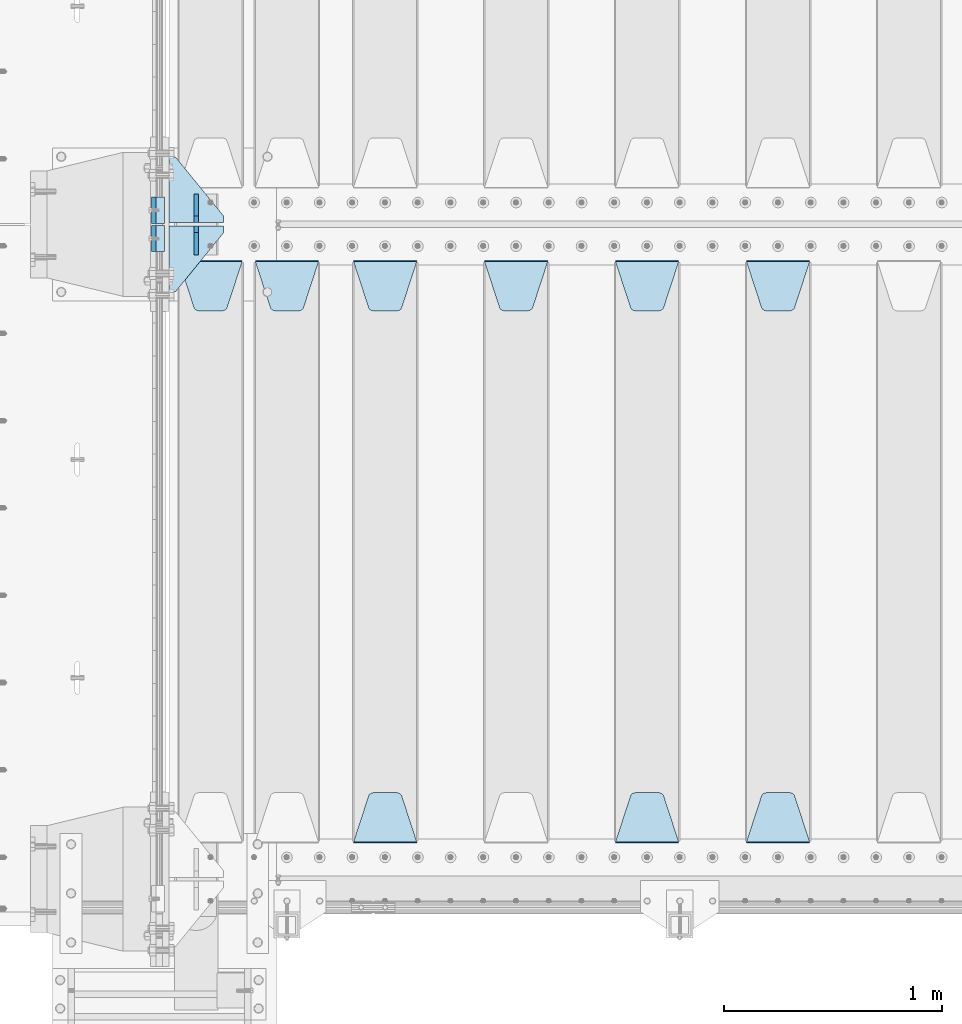
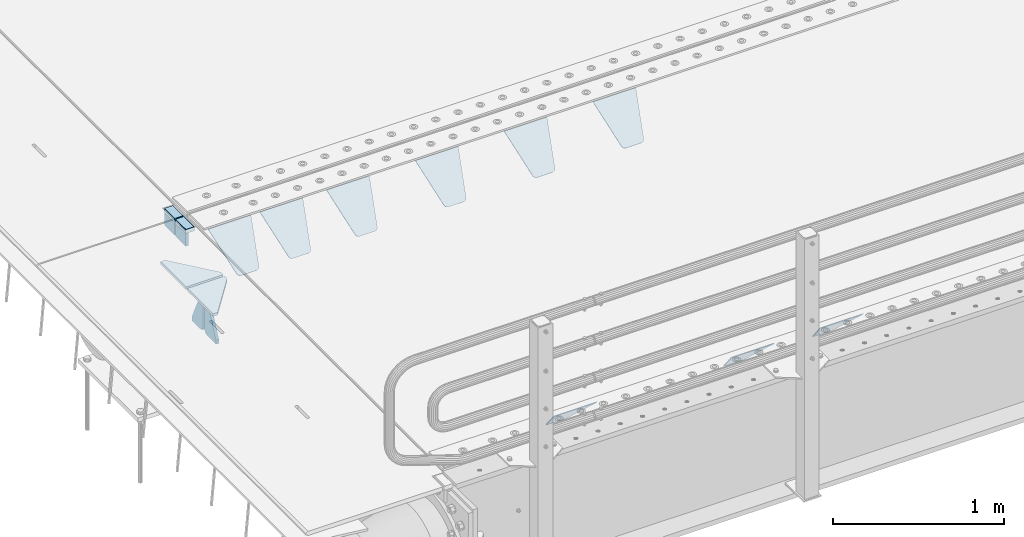
# One storey, part 215 of 270: 17 plates.
"""IFC2X3 building model written with IfcOpenShell, lengths in millimetres."""

from ifc_helpers import new_model, si_unit, frame, origin_with_axes, place, context, subcontext, project, spatial, faceted_brep, material, type_object, element, save


model = new_model("IFC2X3")

# Units and contexts
model_context = context("Model", 3, precision=1e-05, world=origin_with_axes())
body_context = subcontext(model_context, "Body", "Model", "MODEL_VIEW")
ifc_project = project(units=[si_unit("LENGTHUNIT", "METRE", prefix="MILLI"), si_unit("AREAUNIT", "SQUARE_METRE"), si_unit("VOLUMEUNIT", "CUBIC_METRE"), si_unit("MASSUNIT", "GRAM", prefix="KILO"), si_unit("TIMEUNIT", "SECOND"), si_unit("PLANEANGLEUNIT", "RADIAN"), si_unit("SOLIDANGLEUNIT", "STERADIAN"), si_unit("THERMODYNAMICTEMPERATUREUNIT", "DEGREE_CELSIUS"), si_unit("LUMINOUSINTENSITYUNIT", "LUMEN")], contexts=[model_context])

# Site, building, storey
site_placement = place(None, origin_with_axes())
site = spatial("IfcSite", under=ifc_project, at=site_placement, CompositionType="ELEMENT")
building_placement = place(site_placement, origin_with_axes())
building = spatial("IfcBuilding", under=site, at=building_placement, Name="Standard", CompositionType="ELEMENT")
storey_placement = place(building_placement, origin_with_axes())
storey = spatial("IfcBuildingStorey", under=building, at=storey_placement, Name="Undefined", CompositionType="ELEMENT", Elevation=0.0)

# Plates
ifc_material_1 = material()
plate_type_1 = type_object("IfcPlateType", PredefinedType="NOTDEFINED")
plate_1_placement = place(storey_placement, frame((-10.0000000000014, -21064.9999999999, -16.0000945328909), z_axis=(-1.0, 0.0, 0.0), x_axis=(0.0, 0.0, 1.0)))
element("IfcPlate", 1, at=plate_1_placement, inside=storey, type_object=plate_type_1, material=ifc_material_1, context=body_context, shape_type="Brep", body=[
    faceted_brep([(1.77635683940025e-15, -60.0000000000073, 0.0), (2.49929321682885e-09, -60.0000000000073, 60.0), (2.49928966411517e-09, 59.9999999999964, 60.0), (-1.77635683940025e-15, 59.9999999999964, 0.0), (25.0146748218828, -60.0000000000073, 60.0), (25.0146748218828, 59.9999999999927, 60.0), (26.5597449794466, -60.0000000000073, 59.7552873949117), (26.5597449794466, 59.9999999999964, 59.7552873949117), (27.9535758796897, -60.0000000000036, 59.0451032832824), (27.9535758796897, 59.9999999999964, 59.0451032832824), (29.0597323263517, -60.0000000000073, 57.9389640667317), (29.0597323263517, 59.9999999999927, 57.9389640667317), (29.7699381491534, -60.0000000000036, 56.5451442289687), (29.7699381491534, 59.9999999999927, 56.5451442289687), (30.0146748212763, -60.0000000000073, 55.0000778834025), (30.0146748212762, 59.9999999999927, 55.0000778834025), (30.0154536553013, -60.0000000000036, 5.00007788340855), (30.0154536553013, 59.9999999999964, 5.00007788340855), (29.7707554908505, -60.0000000000073, 3.45497428546548), (29.7707554908505, 59.9999999999927, 3.45497428546548), (29.0605660948355, -60.0000000000073, 2.06111154407017), (29.0605660948355, 59.9999999999927, 2.06111154407017), (27.9544051209123, -60.0000000000036, 0.954933339696428), (27.9544051209123, 59.9999999999964, 0.954933339696428), (26.5605534420796, -60.0000000000036, 0.244722232012666), (26.5605534420796, 59.9999999999964, 0.244722232012666), (25.0154536559091, -60.0000000000073, 6.05382410867605e-12), (25.0154536559091, 59.9999999999927, 6.05382410867605e-12)], [[[0, 1, 2, 3]], [[1, 4, 5, 2]], [[4, 6, 7, 5]], [[6, 8, 9, 7]], [[8, 10, 11, 9]], [[10, 12, 13, 11]], [[12, 14, 15, 13]], [[14, 16, 17, 15]], [[16, 18, 19, 17]], [[18, 20, 21, 19]], [[20, 22, 23, 21]], [[22, 24, 25, 23]], [[24, 26, 27, 25]], [[26, 0, 3, 27]], [[5, 7, 9, 11, 13, 15, 17, 19, 21, 23, 25, 27, 3, 2]], [[26, 24, 22, 20, 18, 16, 14, 12, 10, 8, 6, 4, 1, 0]]]),
])
plate_2_placement = place(storey_placement, frame((-10.0000000600267, -20934.9999995478, -16.0145962164398), z_axis=(-1.0, 0.0, 0.0), x_axis=(0.0, -4.95099997756316e-06, 0.999999999987744)))
element("IfcPlate", 2, at=plate_2_placement, inside=storey, type_object=plate_type_1, material=ifc_material_1, context=body_context, shape_type="Brep", body=[
    faceted_brep([(1.77635683940025e-15, -60.0000000000073, 0.0), (-0.000933120085688799, -60.0000000000036, 60.0), (-0.000933120085688799, 59.9999999999964, 60.0), (-1.77635683940025e-15, 59.9999999999964, 0.0), (24.9991450303709, -60.0, 60.0), (24.9991450303709, 59.9999999999964, 60.0), (26.544215218168, -60.0000000000036, 59.7552873850884), (26.544215218168, 60.0, 59.7552873850884), (27.9380461396139, -60.0000000000036, 59.0451032459123), (27.9380461396139, 60.0, 59.0451032459123), (29.0442025908961, -60.0000000000036, 57.9389639895784), (29.0442025908961, 60.0, 57.9389639895784), (29.7544083969366, -60.0, 56.5451441080361), (29.7544083969366, 60.0000000000036, 56.5451441080361), (29.9991450297669, -60.0000000000036, 55.0000777244568), (29.9991450297669, 60.0, 55.0000777244568), (29.999922274335, -60.0, 5.00007772445705), (29.999922274335, 60.0, 5.00007772445704), (29.7552240705896, -60.0000000000036, 3.45497416452589), (29.7552240705896, 60.0, 3.45497416452589), (29.0450346578116, -60.0, 2.06111146690959), (29.0450346578116, 59.9999999999964, 2.0611114669096), (27.9388736885072, -60.0, 0.954933302319514), (27.9388736885072, 59.9999999999964, 0.954933302319516), (26.5450220308766, -60.0000000000036, 0.244722222183089), (26.5450220308766, 60.0, 0.244722222183091), (24.9999222749392, -60.0, 2.66453525910038e-13), (24.9999222749392, 60.0, 2.66453525910038e-13)], [[[0, 1, 2, 3]], [[1, 4, 5, 2]], [[4, 6, 7, 5]], [[6, 8, 9, 7]], [[8, 10, 11, 9]], [[10, 12, 13, 11]], [[12, 14, 15, 13]], [[14, 16, 17, 15]], [[16, 18, 19, 17]], [[18, 20, 21, 19]], [[20, 22, 23, 21]], [[22, 24, 25, 23]], [[24, 26, 27, 25]], [[26, 0, 3, 27]], [[5, 7, 9, 11, 13, 15, 17, 19, 21, 23, 25, 27, 3, 2]], [[26, 24, 22, 20, 18, 16, 14, 12, 10, 8, 6, 4, 1, 0]]]),
])
ifc_material_2 = material(Name="STEEL/S355N")
plate_type_2 = type_object("IfcPlateType", PredefinedType="NOTDEFINED")
plate_3_placement = place(storey_placement, frame((-60.000000000005, -21004.9999144655, -105.984429072951), z_axis=(0.0, -1.0, 0.0), x_axis=(0.0, 0.0, 1.0)))
element("IfcPlate", 3, at=plate_3_placement, inside=storey, type_object=plate_type_2, material=ifc_material_2, context=body_context, shape_type="Brep", body=[
    faceted_brep([(0.0, -10.0, 0.0), (4.30830482400779e-10, -10.0, 120.000000000004), (4.30830482400779e-10, 10.0, 120.000000000004), (0.0, 10.0, 0.0), (89.9845046997066, -10.0, 120.0), (89.9845046997066, 10.0, 120.0), (89.9843902587891, -10.0, 6.54836185276508e-11), (89.9843902587891, 10.0, 6.54836185276508e-11)], [[[0, 1, 2, 3]], [[1, 4, 5, 2]], [[4, 6, 7, 5]], [[6, 0, 3, 7]], [[5, 7, 3, 2]], [[6, 4, 1, 0]]]),
])
plate_4_placement = place(storey_placement, frame((-60.0, -20874.9995539981, -106.014921246643), z_axis=(0.0, -0.999999999987744, -4.95099999993769e-06), x_axis=(0.0, -4.95099997756316e-06, 0.999999999987744)))
element("IfcPlate", 4, at=plate_4_placement, inside=storey, type_object=plate_type_2, material=ifc_material_2, context=body_context, shape_type="Brep", body=[
    faceted_brep([(0.0, -10.0, 0.0), (4.30830482400779e-10, -10.0, 120.000000000004), (4.30830482400779e-10, 10.0, 120.000000000004), (0.0, 10.0, 0.0), (89.9999999999979, -10.0, 120.000000000004), (89.9999999999979, 10.0, 120.000000000004), (90.0, -10.0, 1.09139364212751e-11), (90.0, 10.0, 1.09139364212751e-11)], [[[0, 1, 2, 3]], [[1, 4, 5, 2]], [[4, 6, 7, 5]], [[6, 0, 3, 7]], [[5, 7, 3, 2]], [[6, 4, 1, 0]]]),
])
plate_type_3 = type_object("IfcPlateType", PredefinedType="NOTDEFINED")
plate_5_placement = place(storey_placement, frame((2655.0, -21168.232233044, -1.76776695296576), z_axis=(0.0, -0.707106781186548, -0.707106781186547), x_axis=(1.0, 0.0, 0.0)))
element("IfcPlate", 5, at=plate_5_placement, inside=storey, type_object=plate_type_3, material=ifc_material_2, context=body_context, shape_type="Brep", body=[
    faceted_brep([(0.0, -2.5, 0.0), (69.345504679477, -2.5, 300.171731424831), (69.345504679477, 2.5, 300.171731424831), (0.0, 2.5, 0.0), (70.9274061199576, -2.5, 304.8974424154), (70.9274061199576, 2.5, 304.8974424154), (73.3818627772307, -2.49999999999818, 309.234538108527), (73.3818627772307, 2.50000000000182, 309.234538108527), (76.6187032999551, -2.5, 313.023683126103), (76.6187032999551, 2.5, 313.023683126103), (80.5190132704993, -2.5, 316.125672595372), (80.5190132704993, 2.50000000000182, 316.125672595372), (84.9395038596849, -2.49999999999818, 318.426546230476), (84.9395038596849, 2.5, 318.426546230476), (89.7177759439219, -2.49999999999818, 319.841774983275), (89.7177759439219, 2.50000000000182, 319.841774983275), (94.678286292652, -2.5, 320.319366455078), (94.678286292652, 2.5, 320.319366455078), (195.321713707348, -2.5, 320.319366455078), (195.321713707348, 2.5, 320.319366455078), (200.282224056078, -2.49999999999818, 319.841774983275), (200.282224056078, 2.50000000000182, 319.841774983275), (205.060496140315, -2.5, 318.426546230476), (205.060496140315, 2.5, 318.426546230476), (209.480986729501, -2.5, 316.12567259537), (209.480986729501, 2.50000000000182, 316.12567259537), (213.381296700045, -2.5, 313.023683126103), (213.381296700045, 2.5, 313.023683126103), (216.618137222769, -2.49999999999818, 309.234538108525), (216.618137222769, 2.50000000000182, 309.234538108527), (219.072593880042, -2.49999999999818, 304.897442415398), (219.072593880042, 2.50000000000182, 304.897442415397), (220.654495320523, -2.5, 300.171731424831), (220.654495320523, 2.5, 300.171731424831), (290.0, -2.49999999999818, 0.0), (290.0, 2.5, 0.0)], [[[0, 1, 2, 3]], [[1, 4, 5, 2]], [[4, 6, 7, 5]], [[6, 8, 9, 7]], [[8, 10, 11, 9]], [[10, 12, 13, 11]], [[12, 14, 15, 13]], [[14, 16, 17, 15]], [[16, 18, 19, 17]], [[18, 20, 21, 19]], [[20, 22, 23, 21]], [[22, 24, 25, 23]], [[24, 26, 27, 25]], [[26, 28, 29, 27]], [[28, 30, 31, 29]], [[30, 32, 33, 31]], [[32, 34, 35, 33]], [[34, 0, 3, 35]], [[5, 7, 9, 11, 13, 15, 17, 19, 21, 23, 25, 27, 29, 31, 33, 35, 3, 2]], [[34, 32, 30, 28, 26, 24, 22, 20, 18, 16, 14, 12, 10, 8, 6, 4, 1, 0]]]),
])
plate_6_placement = place(storey_placement, frame((2945.0, -23831.767766953, -1.76776695296758), z_axis=(0.0, 0.707106781186547, -0.707106781186548), x_axis=(-1.0, 0.0, 0.0)))
element("IfcPlate", 6, at=plate_6_placement, inside=storey, type_object=plate_type_3, material=ifc_material_2, context=body_context, shape_type="Brep", body=[
    faceted_brep([(0.0, -2.5, 0.0), (69.345504679477, -2.5, 300.171731424831), (69.345504679477, 2.5, 300.171731424831), (0.0, 2.5, 0.0), (70.9274061199576, -2.5, 304.8974424154), (70.9274061199576, 2.5, 304.8974424154), (73.3818627772307, -2.49999999999818, 309.234538108527), (73.3818627772307, 2.50000000000182, 309.234538108527), (76.6187032999551, -2.5, 313.023683126103), (76.6187032999551, 2.5, 313.023683126103), (80.5190132704993, -2.5, 316.125672595372), (80.5190132704993, 2.50000000000182, 316.125672595372), (84.9395038596849, -2.49999999999818, 318.426546230476), (84.9395038596849, 2.5, 318.426546230476), (89.7177759439219, -2.49999999999818, 319.841774983275), (89.7177759439219, 2.50000000000182, 319.841774983275), (94.678286292652, -2.5, 320.319366455078), (94.678286292652, 2.5, 320.319366455078), (195.321713707348, -2.5, 320.319366455078), (195.321713707348, 2.5, 320.319366455078), (200.282224056078, -2.49999999999818, 319.841774983275), (200.282224056078, 2.50000000000182, 319.841774983275), (205.060496140315, -2.5, 318.426546230476), (205.060496140315, 2.5, 318.426546230476), (209.480986729501, -2.5, 316.12567259537), (209.480986729501, 2.50000000000182, 316.12567259537), (213.381296700045, -2.5, 313.023683126103), (213.381296700045, 2.5, 313.023683126103), (216.618137222769, -2.49999999999818, 309.234538108525), (216.618137222769, 2.50000000000182, 309.234538108527), (219.072593880042, -2.49999999999818, 304.897442415398), (219.072593880042, 2.50000000000182, 304.897442415397), (220.654495320523, -2.5, 300.171731424831), (220.654495320523, 2.5, 300.171731424831), (290.0, -2.49999999999818, 0.0), (290.0, 2.5, 0.0)], [[[0, 1, 2, 3]], [[1, 4, 5, 2]], [[4, 6, 7, 5]], [[6, 8, 9, 7]], [[8, 10, 11, 9]], [[10, 12, 13, 11]], [[12, 14, 15, 13]], [[14, 16, 17, 15]], [[16, 18, 19, 17]], [[18, 20, 21, 19]], [[20, 22, 23, 21]], [[22, 24, 25, 23]], [[24, 26, 27, 25]], [[26, 28, 29, 27]], [[28, 30, 31, 29]], [[30, 32, 33, 31]], [[32, 34, 35, 33]], [[34, 0, 3, 35]], [[5, 7, 9, 11, 13, 15, 17, 19, 21, 23, 25, 27, 29, 31, 33, 35, 3, 2]], [[34, 32, 30, 28, 26, 24, 22, 20, 18, 16, 14, 12, 10, 8, 6, 4, 1, 0]]]),
])
plate_7_placement = place(storey_placement, frame((2055.0, -21168.232233044, -1.76776695296576), z_axis=(0.0, -0.707106781186548, -0.707106781186547), x_axis=(1.0, 0.0, 0.0)))
element("IfcPlate", 7, at=plate_7_placement, inside=storey, type_object=plate_type_3, material=ifc_material_2, context=body_context, shape_type="Brep", body=[
    faceted_brep([(0.0, -2.5, 0.0), (69.345504679477, -2.5, 300.171731424831), (69.345504679477, 2.5, 300.171731424831), (0.0, 2.5, 0.0), (70.9274061199576, -2.5, 304.8974424154), (70.9274061199576, 2.5, 304.8974424154), (73.3818627772307, -2.49999999999818, 309.234538108527), (73.3818627772307, 2.50000000000182, 309.234538108527), (76.6187032999551, -2.5, 313.023683126103), (76.6187032999551, 2.5, 313.023683126103), (80.5190132704993, -2.5, 316.125672595372), (80.5190132704993, 2.50000000000182, 316.125672595372), (84.9395038596849, -2.49999999999818, 318.426546230476), (84.9395038596849, 2.5, 318.426546230476), (89.7177759439219, -2.49999999999818, 319.841774983275), (89.7177759439219, 2.50000000000182, 319.841774983275), (94.678286292652, -2.5, 320.319366455078), (94.678286292652, 2.5, 320.319366455078), (195.321713707348, -2.5, 320.319366455078), (195.321713707348, 2.5, 320.319366455078), (200.282224056078, -2.49999999999818, 319.841774983275), (200.282224056078, 2.50000000000182, 319.841774983275), (205.060496140315, -2.5, 318.426546230476), (205.060496140315, 2.5, 318.426546230476), (209.480986729501, -2.5, 316.12567259537), (209.480986729501, 2.50000000000182, 316.12567259537), (213.381296700045, -2.5, 313.023683126103), (213.381296700045, 2.5, 313.023683126103), (216.618137222769, -2.49999999999818, 309.234538108525), (216.618137222769, 2.50000000000182, 309.234538108527), (219.072593880042, -2.49999999999818, 304.897442415398), (219.072593880042, 2.50000000000182, 304.897442415397), (220.654495320523, -2.5, 300.171731424831), (220.654495320523, 2.5, 300.171731424831), (290.0, -2.49999999999818, 0.0), (290.0, 2.5, 0.0)], [[[0, 1, 2, 3]], [[1, 4, 5, 2]], [[4, 6, 7, 5]], [[6, 8, 9, 7]], [[8, 10, 11, 9]], [[10, 12, 13, 11]], [[12, 14, 15, 13]], [[14, 16, 17, 15]], [[16, 18, 19, 17]], [[18, 20, 21, 19]], [[20, 22, 23, 21]], [[22, 24, 25, 23]], [[24, 26, 27, 25]], [[26, 28, 29, 27]], [[28, 30, 31, 29]], [[30, 32, 33, 31]], [[32, 34, 35, 33]], [[34, 0, 3, 35]], [[5, 7, 9, 11, 13, 15, 17, 19, 21, 23, 25, 27, 29, 31, 33, 35, 3, 2]], [[34, 32, 30, 28, 26, 24, 22, 20, 18, 16, 14, 12, 10, 8, 6, 4, 1, 0]]]),
])
plate_8_placement = place(storey_placement, frame((2345.0, -23831.767766953, -1.76776695296758), z_axis=(0.0, 0.707106781186547, -0.707106781186548), x_axis=(-1.0, 0.0, 0.0)))
element("IfcPlate", 8, at=plate_8_placement, inside=storey, type_object=plate_type_3, material=ifc_material_2, context=body_context, shape_type="Brep", body=[
    faceted_brep([(0.0, -2.5, 0.0), (69.345504679477, -2.5, 300.171731424831), (69.345504679477, 2.5, 300.171731424831), (0.0, 2.5, 0.0), (70.9274061199576, -2.5, 304.8974424154), (70.9274061199576, 2.5, 304.8974424154), (73.3818627772307, -2.49999999999818, 309.234538108527), (73.3818627772307, 2.50000000000182, 309.234538108527), (76.6187032999551, -2.5, 313.023683126103), (76.6187032999551, 2.5, 313.023683126103), (80.5190132704993, -2.5, 316.125672595372), (80.5190132704993, 2.50000000000182, 316.125672595372), (84.9395038596849, -2.49999999999818, 318.426546230476), (84.9395038596849, 2.5, 318.426546230476), (89.7177759439219, -2.49999999999818, 319.841774983275), (89.7177759439219, 2.50000000000182, 319.841774983275), (94.678286292652, -2.5, 320.319366455078), (94.678286292652, 2.5, 320.319366455078), (195.321713707348, -2.5, 320.319366455078), (195.321713707348, 2.5, 320.319366455078), (200.282224056078, -2.49999999999818, 319.841774983275), (200.282224056078, 2.50000000000182, 319.841774983275), (205.060496140315, -2.5, 318.426546230476), (205.060496140315, 2.5, 318.426546230476), (209.480986729501, -2.5, 316.12567259537), (209.480986729501, 2.50000000000182, 316.12567259537), (213.381296700045, -2.5, 313.023683126103), (213.381296700045, 2.5, 313.023683126103), (216.618137222769, -2.49999999999818, 309.234538108525), (216.618137222769, 2.50000000000182, 309.234538108527), (219.072593880042, -2.49999999999818, 304.897442415398), (219.072593880042, 2.50000000000182, 304.897442415397), (220.654495320523, -2.5, 300.171731424831), (220.654495320523, 2.5, 300.171731424831), (290.0, -2.49999999999818, 0.0), (290.0, 2.5, 0.0)], [[[0, 1, 2, 3]], [[1, 4, 5, 2]], [[4, 6, 7, 5]], [[6, 8, 9, 7]], [[8, 10, 11, 9]], [[10, 12, 13, 11]], [[12, 14, 15, 13]], [[14, 16, 17, 15]], [[16, 18, 19, 17]], [[18, 20, 21, 19]], [[20, 22, 23, 21]], [[22, 24, 25, 23]], [[24, 26, 27, 25]], [[26, 28, 29, 27]], [[28, 30, 31, 29]], [[30, 32, 33, 31]], [[32, 34, 35, 33]], [[34, 0, 3, 35]], [[5, 7, 9, 11, 13, 15, 17, 19, 21, 23, 25, 27, 29, 31, 33, 35, 3, 2]], [[34, 32, 30, 28, 26, 24, 22, 20, 18, 16, 14, 12, 10, 8, 6, 4, 1, 0]]]),
])
plate_9_placement = place(storey_placement, frame((1455.0, -21168.232233044, -1.76776695296576), z_axis=(0.0, -0.707106781186548, -0.707106781186547), x_axis=(1.0, 0.0, 0.0)))
element("IfcPlate", 9, at=plate_9_placement, inside=storey, type_object=plate_type_3, material=ifc_material_2, context=body_context, shape_type="Brep", body=[
    faceted_brep([(0.0, -2.5, 0.0), (69.345504679477, -2.5, 300.171731424831), (69.345504679477, 2.5, 300.171731424831), (0.0, 2.5, 0.0), (70.9274061199576, -2.5, 304.8974424154), (70.9274061199576, 2.5, 304.8974424154), (73.3818627772307, -2.49999999999818, 309.234538108527), (73.3818627772307, 2.50000000000182, 309.234538108527), (76.6187032999551, -2.5, 313.023683126103), (76.6187032999551, 2.5, 313.023683126103), (80.5190132704993, -2.5, 316.125672595372), (80.5190132704993, 2.50000000000182, 316.125672595372), (84.9395038596849, -2.49999999999818, 318.426546230476), (84.9395038596849, 2.5, 318.426546230476), (89.7177759439219, -2.49999999999818, 319.841774983275), (89.7177759439219, 2.50000000000182, 319.841774983275), (94.678286292652, -2.5, 320.319366455078), (94.678286292652, 2.5, 320.319366455078), (195.321713707348, -2.5, 320.319366455078), (195.321713707348, 2.5, 320.319366455078), (200.282224056078, -2.49999999999818, 319.841774983275), (200.282224056078, 2.50000000000182, 319.841774983275), (205.060496140315, -2.5, 318.426546230476), (205.060496140315, 2.5, 318.426546230476), (209.480986729501, -2.5, 316.12567259537), (209.480986729501, 2.50000000000182, 316.12567259537), (213.381296700045, -2.5, 313.023683126103), (213.381296700045, 2.5, 313.023683126103), (216.618137222769, -2.49999999999818, 309.234538108525), (216.618137222769, 2.50000000000182, 309.234538108527), (219.072593880042, -2.49999999999818, 304.897442415398), (219.072593880042, 2.50000000000182, 304.897442415397), (220.654495320523, -2.5, 300.171731424831), (220.654495320523, 2.5, 300.171731424831), (290.0, -2.49999999999818, 0.0), (290.0, 2.5, 0.0)], [[[0, 1, 2, 3]], [[1, 4, 5, 2]], [[4, 6, 7, 5]], [[6, 8, 9, 7]], [[8, 10, 11, 9]], [[10, 12, 13, 11]], [[12, 14, 15, 13]], [[14, 16, 17, 15]], [[16, 18, 19, 17]], [[18, 20, 21, 19]], [[20, 22, 23, 21]], [[22, 24, 25, 23]], [[24, 26, 27, 25]], [[26, 28, 29, 27]], [[28, 30, 31, 29]], [[30, 32, 33, 31]], [[32, 34, 35, 33]], [[34, 0, 3, 35]], [[5, 7, 9, 11, 13, 15, 17, 19, 21, 23, 25, 27, 29, 31, 33, 35, 3, 2]], [[34, 32, 30, 28, 26, 24, 22, 20, 18, 16, 14, 12, 10, 8, 6, 4, 1, 0]]]),
])
plate_10_placement = place(storey_placement, frame((855.0, -21168.232233044, -1.76776695296576), z_axis=(0.0, -0.707106781186548, -0.707106781186547), x_axis=(1.0, 0.0, 0.0)))
element("IfcPlate", 10, at=plate_10_placement, inside=storey, type_object=plate_type_3, material=ifc_material_2, context=body_context, shape_type="Brep", body=[
    faceted_brep([(0.0, -2.5, 0.0), (69.345504679477, -2.5, 300.171731424831), (69.345504679477, 2.5, 300.171731424831), (0.0, 2.5, 0.0), (70.9274061199576, -2.5, 304.8974424154), (70.9274061199576, 2.5, 304.8974424154), (73.3818627772307, -2.49999999999818, 309.234538108527), (73.3818627772307, 2.50000000000182, 309.234538108527), (76.6187032999551, -2.5, 313.023683126103), (76.6187032999551, 2.5, 313.023683126103), (80.5190132704993, -2.5, 316.125672595372), (80.5190132704993, 2.50000000000182, 316.125672595372), (84.9395038596849, -2.49999999999818, 318.426546230476), (84.9395038596849, 2.5, 318.426546230476), (89.7177759439219, -2.49999999999818, 319.841774983275), (89.7177759439219, 2.50000000000182, 319.841774983275), (94.678286292652, -2.5, 320.319366455078), (94.678286292652, 2.5, 320.319366455078), (195.321713707348, -2.5, 320.319366455078), (195.321713707348, 2.5, 320.319366455078), (200.282224056078, -2.49999999999818, 319.841774983275), (200.282224056078, 2.50000000000182, 319.841774983275), (205.060496140315, -2.5, 318.426546230476), (205.060496140315, 2.5, 318.426546230476), (209.480986729501, -2.5, 316.12567259537), (209.480986729501, 2.50000000000182, 316.12567259537), (213.381296700045, -2.5, 313.023683126103), (213.381296700045, 2.5, 313.023683126103), (216.618137222769, -2.49999999999818, 309.234538108525), (216.618137222769, 2.50000000000182, 309.234538108527), (219.072593880042, -2.49999999999818, 304.897442415398), (219.072593880042, 2.50000000000182, 304.897442415397), (220.654495320523, -2.5, 300.171731424831), (220.654495320523, 2.5, 300.171731424831), (290.0, -2.49999999999818, 0.0), (290.0, 2.5, 0.0)], [[[0, 1, 2, 3]], [[1, 4, 5, 2]], [[4, 6, 7, 5]], [[6, 8, 9, 7]], [[8, 10, 11, 9]], [[10, 12, 13, 11]], [[12, 14, 15, 13]], [[14, 16, 17, 15]], [[16, 18, 19, 17]], [[18, 20, 21, 19]], [[20, 22, 23, 21]], [[22, 24, 25, 23]], [[24, 26, 27, 25]], [[26, 28, 29, 27]], [[28, 30, 31, 29]], [[30, 32, 33, 31]], [[32, 34, 35, 33]], [[34, 0, 3, 35]], [[5, 7, 9, 11, 13, 15, 17, 19, 21, 23, 25, 27, 29, 31, 33, 35, 3, 2]], [[34, 32, 30, 28, 26, 24, 22, 20, 18, 16, 14, 12, 10, 8, 6, 4, 1, 0]]]),
])
plate_11_placement = place(storey_placement, frame((1145.0, -23831.767766953, -1.76776695296758), z_axis=(0.0, 0.707106781186547, -0.707106781186548), x_axis=(-1.0, 0.0, 0.0)))
element("IfcPlate", 11, at=plate_11_placement, inside=storey, type_object=plate_type_3, material=ifc_material_2, context=body_context, shape_type="Brep", body=[
    faceted_brep([(0.0, -2.5, 0.0), (69.345504679477, -2.5, 300.171731424831), (69.345504679477, 2.5, 300.171731424831), (0.0, 2.5, 0.0), (70.9274061199576, -2.5, 304.8974424154), (70.9274061199576, 2.5, 304.8974424154), (73.3818627772307, -2.49999999999818, 309.234538108527), (73.3818627772307, 2.50000000000182, 309.234538108527), (76.6187032999551, -2.5, 313.023683126103), (76.6187032999551, 2.5, 313.023683126103), (80.5190132704993, -2.5, 316.125672595372), (80.5190132704993, 2.50000000000182, 316.125672595372), (84.9395038596849, -2.49999999999818, 318.426546230476), (84.9395038596849, 2.5, 318.426546230476), (89.7177759439219, -2.49999999999818, 319.841774983275), (89.7177759439219, 2.50000000000182, 319.841774983275), (94.678286292652, -2.5, 320.319366455078), (94.678286292652, 2.5, 320.319366455078), (195.321713707348, -2.5, 320.319366455078), (195.321713707348, 2.5, 320.319366455078), (200.282224056078, -2.49999999999818, 319.841774983275), (200.282224056078, 2.50000000000182, 319.841774983275), (205.060496140315, -2.5, 318.426546230476), (205.060496140315, 2.5, 318.426546230476), (209.480986729501, -2.5, 316.12567259537), (209.480986729501, 2.50000000000182, 316.12567259537), (213.381296700045, -2.5, 313.023683126103), (213.381296700045, 2.5, 313.023683126103), (216.618137222769, -2.49999999999818, 309.234538108525), (216.618137222769, 2.50000000000182, 309.234538108527), (219.072593880042, -2.49999999999818, 304.897442415398), (219.072593880042, 2.50000000000182, 304.897442415397), (220.654495320523, -2.5, 300.171731424831), (220.654495320523, 2.5, 300.171731424831), (290.0, -2.49999999999818, 0.0), (290.0, 2.5, 0.0)], [[[0, 1, 2, 3]], [[1, 4, 5, 2]], [[4, 6, 7, 5]], [[6, 8, 9, 7]], [[8, 10, 11, 9]], [[10, 12, 13, 11]], [[12, 14, 15, 13]], [[14, 16, 17, 15]], [[16, 18, 19, 17]], [[18, 20, 21, 19]], [[20, 22, 23, 21]], [[22, 24, 25, 23]], [[24, 26, 27, 25]], [[26, 28, 29, 27]], [[28, 30, 31, 29]], [[30, 32, 33, 31]], [[32, 34, 35, 33]], [[34, 0, 3, 35]], [[5, 7, 9, 11, 13, 15, 17, 19, 21, 23, 25, 27, 29, 31, 33, 35, 3, 2]], [[34, 32, 30, 28, 26, 24, 22, 20, 18, 16, 14, 12, 10, 8, 6, 4, 1, 0]]]),
])
plate_12_placement = place(storey_placement, frame((405.0, -21168.232233044, -1.76776695296576), z_axis=(0.0, -0.707106781186548, -0.707106781186547), x_axis=(1.0, 0.0, 0.0)))
element("IfcPlate", 12, at=plate_12_placement, inside=storey, type_object=plate_type_3, material=ifc_material_2, context=body_context, shape_type="Brep", body=[
    faceted_brep([(0.0, -2.5, 0.0), (69.345504679477, -2.5, 300.171731424831), (69.345504679477, 2.5, 300.171731424831), (0.0, 2.5, 0.0), (70.9274061199576, -2.5, 304.8974424154), (70.9274061199576, 2.5, 304.8974424154), (73.3818627772307, -2.49999999999818, 309.234538108527), (73.3818627772307, 2.50000000000182, 309.234538108527), (76.6187032999551, -2.5, 313.023683126103), (76.6187032999551, 2.5, 313.023683126103), (80.5190132704993, -2.5, 316.125672595372), (80.5190132704993, 2.50000000000182, 316.125672595372), (84.9395038596849, -2.49999999999818, 318.426546230476), (84.9395038596849, 2.5, 318.426546230476), (89.7177759439219, -2.49999999999818, 319.841774983275), (89.7177759439219, 2.50000000000182, 319.841774983275), (94.678286292652, -2.5, 320.319366455078), (94.678286292652, 2.5, 320.319366455078), (195.321713707348, -2.5, 320.319366455078), (195.321713707348, 2.5, 320.319366455078), (200.282224056078, -2.49999999999818, 319.841774983275), (200.282224056078, 2.50000000000182, 319.841774983275), (205.060496140315, -2.5, 318.426546230476), (205.060496140315, 2.5, 318.426546230476), (209.480986729501, -2.5, 316.12567259537), (209.480986729501, 2.50000000000182, 316.12567259537), (213.381296700045, -2.5, 313.023683126103), (213.381296700045, 2.5, 313.023683126103), (216.618137222769, -2.49999999999818, 309.234538108525), (216.618137222769, 2.50000000000182, 309.234538108527), (219.072593880042, -2.49999999999818, 304.897442415398), (219.072593880042, 2.50000000000182, 304.897442415397), (220.654495320523, -2.5, 300.171731424831), (220.654495320523, 2.5, 300.171731424831), (290.0, -2.49999999999818, 0.0), (290.0, 2.5, 0.0)], [[[0, 1, 2, 3]], [[1, 4, 5, 2]], [[4, 6, 7, 5]], [[6, 8, 9, 7]], [[8, 10, 11, 9]], [[10, 12, 13, 11]], [[12, 14, 15, 13]], [[14, 16, 17, 15]], [[16, 18, 19, 17]], [[18, 20, 21, 19]], [[20, 22, 23, 21]], [[22, 24, 25, 23]], [[24, 26, 27, 25]], [[26, 28, 29, 27]], [[28, 30, 31, 29]], [[30, 32, 33, 31]], [[32, 34, 35, 33]], [[34, 0, 3, 35]], [[5, 7, 9, 11, 13, 15, 17, 19, 21, 23, 25, 27, 29, 31, 33, 35, 3, 2]], [[34, 32, 30, 28, 26, 24, 22, 20, 18, 16, 14, 12, 10, 8, 6, 4, 1, 0]]]),
])
plate_13_placement = place(storey_placement, frame((55.0, -21168.232233044, -1.76776695296576), z_axis=(0.0, -0.707106781186548, -0.707106781186547), x_axis=(1.0, 0.0, 0.0)))
element("IfcPlate", 13, at=plate_13_placement, inside=storey, type_object=plate_type_3, material=ifc_material_2, context=body_context, shape_type="Brep", body=[
    faceted_brep([(0.0, -2.5, 0.0), (69.345504679477, -2.5, 300.171731424831), (69.345504679477, 2.5, 300.171731424831), (0.0, 2.5, 0.0), (70.9274061199576, -2.5, 304.8974424154), (70.9274061199576, 2.5, 304.8974424154), (73.3818627772307, -2.49999999999818, 309.234538108527), (73.3818627772307, 2.50000000000182, 309.234538108527), (76.6187032999551, -2.5, 313.023683126103), (76.6187032999551, 2.5, 313.023683126103), (80.5190132704993, -2.5, 316.125672595372), (80.5190132704993, 2.50000000000182, 316.125672595372), (84.9395038596849, -2.49999999999818, 318.426546230476), (84.9395038596849, 2.5, 318.426546230476), (89.7177759439219, -2.49999999999818, 319.841774983275), (89.7177759439219, 2.50000000000182, 319.841774983275), (94.678286292652, -2.5, 320.319366455078), (94.678286292652, 2.5, 320.319366455078), (195.321713707348, -2.5, 320.319366455078), (195.321713707348, 2.5, 320.319366455078), (200.282224056078, -2.49999999999818, 319.841774983275), (200.282224056078, 2.50000000000182, 319.841774983275), (205.060496140315, -2.5, 318.426546230476), (205.060496140315, 2.5, 318.426546230476), (209.480986729501, -2.5, 316.12567259537), (209.480986729501, 2.50000000000182, 316.12567259537), (213.381296700045, -2.5, 313.023683126103), (213.381296700045, 2.5, 313.023683126103), (216.618137222769, -2.49999999999818, 309.234538108525), (216.618137222769, 2.50000000000182, 309.234538108527), (219.072593880042, -2.49999999999818, 304.897442415398), (219.072593880042, 2.50000000000182, 304.897442415397), (220.654495320523, -2.5, 300.171731424831), (220.654495320523, 2.5, 300.171731424831), (290.0, -2.49999999999818, 0.0), (290.0, 2.5, 0.0)], [[[0, 1, 2, 3]], [[1, 4, 5, 2]], [[4, 6, 7, 5]], [[6, 8, 9, 7]], [[8, 10, 11, 9]], [[10, 12, 13, 11]], [[12, 14, 15, 13]], [[14, 16, 17, 15]], [[16, 18, 19, 17]], [[18, 20, 21, 19]], [[20, 22, 23, 21]], [[22, 24, 25, 23]], [[24, 26, 27, 25]], [[26, 28, 29, 27]], [[28, 30, 31, 29]], [[30, 32, 33, 31]], [[32, 34, 35, 33]], [[34, 0, 3, 35]], [[5, 7, 9, 11, 13, 15, 17, 19, 21, 23, 25, 27, 29, 31, 33, 35, 3, 2]], [[34, 32, 30, 28, 26, 24, 22, 20, 18, 16, 14, 12, 10, 8, 6, 4, 1, 0]]]),
])
plate_type_4 = type_object("IfcPlateType", PredefinedType="NOTDEFINED")
for number, where, z_axis, x_axis in (
    (14, (260.0, -20992.0, -515.0), (0.0, 1.0, 0.0), (-1.0, 0.0, 0.0)),
    (15, (259.999999999999, -21008.0, -515.0), (0.0, -1.0, 0.0), (-1.0, 0.0, 0.0)),
):
    element("IfcPlate", number, at=place(storey_placement, frame(where, z_axis=z_axis, x_axis=x_axis)), inside=storey, type_object=plate_type_4, material=ifc_material_2, context=body_context, shape_type="Brep", body=[
        faceted_brep([(0.0, -10.0, 0.0), (0.0, -10.0, 30.0), (0.0, 10.0, 30.0), (0.0, 10.0, 0.0), (220.0, -10.0, 300.0), (220.0, 10.0, 300.0), (250.0, -10.0, 300.0), (250.0, 10.0, 300.0), (250.0, -10.0, 0.0), (250.0, 10.0, 0.0)], [[[0, 1, 2, 3]], [[1, 4, 5, 2]], [[4, 6, 7, 5]], [[6, 8, 9, 7]], [[8, 0, 3, 9]], [[5, 7, 9, 3, 2]], [[8, 6, 4, 1, 0]]]),
    ])
plate_type_5 = type_object("IfcPlateType", PredefinedType="NOTDEFINED")
for number, where, z_axis, x_axis in (
    (16, (135.000000000004, -20860.0, -865.0), (0.0, 0.0, 1.0), (0.0, -1.0, 0.0)),
    (17, (135.000000000004, -21140.0, -865.0), (0.0, 0.0, 1.0), (0.0, 1.0, 0.0)),
):
    element("IfcPlate", number, at=place(storey_placement, frame(where, z_axis=z_axis, x_axis=x_axis)), inside=storey, type_object=plate_type_5, material=ifc_material_2, context=body_context, shape_type="Brep", body=[
        faceted_brep([(0.0, -10.0, 0.0), (0.0, -10.0, 30.0), (0.0, 10.0, 30.0), (0.0, 10.0, 0.0), (102.0, -10.0, 250.0), (102.0, 10.0, 250.0), (132.0, -10.0, 250.0), (132.0, 10.0, 250.0), (132.0, -10.0, 30.0), (132.0, 10.0, 30.0), (131.544232590368, -10.0, 24.790554669992), (131.544232590368, 10.0, 24.790554669992), (130.190778623579, -10.0, 19.7393957002299), (130.190778623579, 10.0, 19.7393957002299), (127.980762113533, -10.0, 15.0), (127.980762113533, 10.0, 15.0), (124.98133329357, -10.0, 10.7163717094038), (124.98133329357, 10.0, 10.7163717094038), (121.283628290596, -10.0, 7.01866670643062), (121.283628290596, 10.0, 7.01866670643062), (117.0, -10.0, 4.01923788646684), (117.0, 10.0, 4.01923788646684), (112.260604299769, -10.0, 1.80922137642278), (112.260604299769, 10.0, 1.80922137642278), (107.209445330009, -10.0, 0.455767409633722), (107.209445330009, 10.0, 0.455767409633722), (102.0, -10.0, 0.0), (102.0, 10.0, 0.0)], [[[0, 1, 2, 3]], [[1, 4, 5, 2]], [[4, 6, 7, 5]], [[6, 8, 9, 7]], [[8, 10, 11, 9]], [[10, 12, 13, 11]], [[12, 14, 15, 13]], [[14, 16, 17, 15]], [[16, 18, 19, 17]], [[18, 20, 21, 19]], [[20, 22, 23, 21]], [[22, 24, 25, 23]], [[24, 26, 27, 25]], [[26, 0, 3, 27]], [[5, 7, 9, 11, 13, 15, 17, 19, 21, 23, 25, 27, 3, 2]], [[26, 24, 22, 20, 18, 16, 14, 12, 10, 8, 6, 4, 1, 0]]]),
    ])

save(model, "model.ifc")
